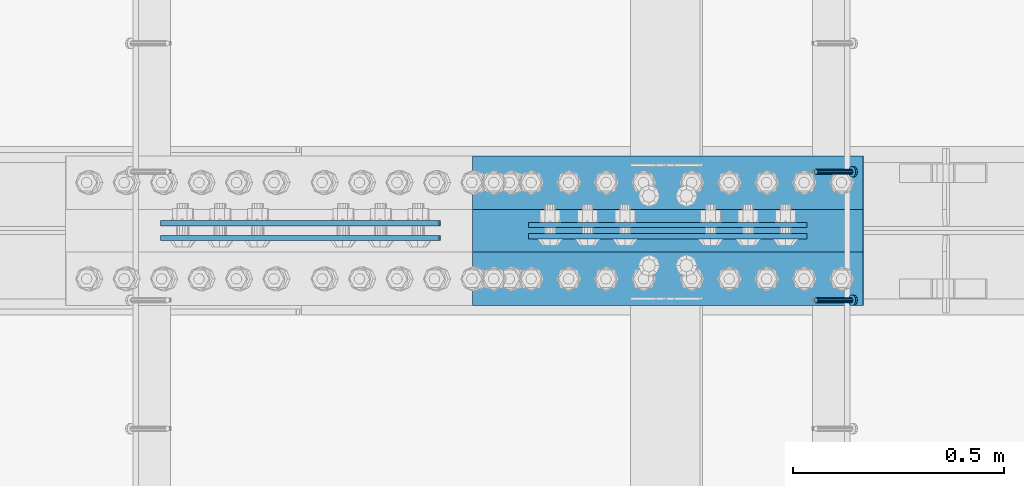
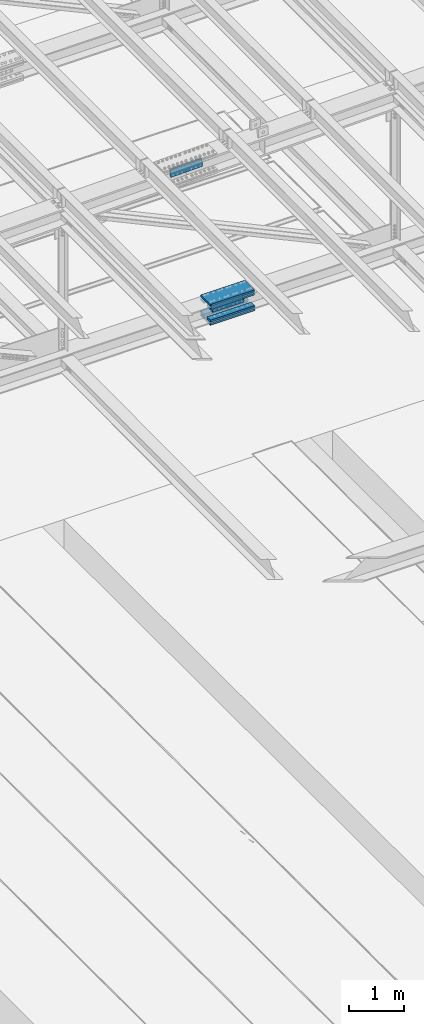
# One storey, part 2254 of 3843: 10 beams, 2 members, 3 elements without a shape of their own.
"""IFC2X3 building model written with IfcOpenShell, lengths in millimetres."""

import ifcopenshell
import ifcopenshell.guid

model = None  # the IFC model being written
_history = None  # IfcOwnerHistory: only IFC2X3 demands one
_inside = {}  # id of a spatial element -> (the spatial element, [elements in it])
_under = {}  # id of a project, library or spatial element -> (it, [spatial elements below it])
_declared = {}  # id of a project -> (the project, [libraries it declares])
_typed = {}  # id of a type object -> (the type object, [elements of that type])
_made_of = {}  # id of a material, layer set ... -> (it, [elements and type objects made of it])


def new_model(schema):
    """Start an empty IFC model of exactly this schema.

    Asked for "IFC4X3", IfcOpenShell would pick the latest addendum, in which some entities
    have other attributes; the version numbers below select the first issue.
    IFC2X3 requires an IfcOwnerHistory on every rooted entity: one is made here for all.
    """
    global model, _history
    if schema == "IFC4X3":
        model = ifcopenshell.file(schema_version=(4, 3, 0, 0))
    else:
        model = ifcopenshell.file(schema=schema)
    _inside.clear()
    _under.clear()
    _declared.clear()
    _typed.clear()
    _made_of.clear()
    _history = None
    if model.schema == "IFC2X3":
        org = make("IfcOrganization", Name="unknown")
        user = make(
            "IfcPersonAndOrganization",
            ThePerson=make("IfcPerson", FamilyName="unknown"),
            TheOrganization=org,
        )
        app = make(
            "IfcApplication",
            ApplicationDeveloper=org,
            Version="unknown",
            ApplicationFullName="unknown",
            ApplicationIdentifier="unknown",
        )
        _history = make(
            "IfcOwnerHistory",
            OwningUser=user,
            OwningApplication=app,
            ChangeAction="ADDED",
            CreationDate=0,
        )
    return model


def make(cls, **values):
    """One entity of the class cls with the attributes given. An attribute that is None is left unset."""
    return model.create_entity(
        cls, **{name: value for name, value in values.items() if value is not None}
    )


def rooted(cls, **values):
    """An entity with a GlobalId (a new one), such as an element, a storey or a relation."""
    return make(cls, GlobalId=ifcopenshell.guid.new(), OwnerHistory=_history, **values)


def si_unit(unit_type, name, prefix=None):
    """IfcSIUnit, for example si_unit("LENGTHUNIT", "METRE", prefix="MILLI")."""
    return make("IfcSIUnit", UnitType=unit_type, Prefix=prefix, Name=name)


def assignment(units):
    """IfcUnitAssignment: the units of a project."""
    return None if units is None else make("IfcUnitAssignment", Units=units)


def point(xyz):
    """IfcCartesianPoint."""
    return None if xyz is None else make("IfcCartesianPoint", Coordinates=xyz)


def direction(xyz):
    """IfcDirection."""
    return None if xyz is None else make("IfcDirection", DirectionRatios=xyz)


def frame(location, z_axis=None, x_axis=None):
    """IfcAxis2Placement3D, a coordinate frame: its origin and axes. An axis left out is left unset."""
    return make(
        "IfcAxis2Placement3D",
        Location=point(location),
        Axis=direction(z_axis),
        RefDirection=direction(x_axis),
    )


def origin_with_axes():
    """The frame at (0, 0, 0) with the z axis (0, 0, 1) and the x axis (1, 0, 0) written out."""
    return frame((0.0, 0.0, 0.0), z_axis=(0.0, 0.0, 1.0), x_axis=(1.0, 0.0, 0.0))


def place(relative_to, where):
    """IfcLocalPlacement: puts the frame where relative to a parent placement (None: the world)."""
    return make(
        "IfcLocalPlacement", PlacementRelTo=relative_to, RelativePlacement=where
    )


def context(
    kind, dimensions, precision=None, world=None, true_north=None, identifier=None
):
    """IfcGeometricRepresentationContext, for example the 3D "Model" context."""
    return make(
        "IfcGeometricRepresentationContext",
        ContextIdentifier=identifier,
        ContextType=kind,
        CoordinateSpaceDimension=dimensions,
        Precision=precision,
        WorldCoordinateSystem=world,
        TrueNorth=true_north,
    )


def subcontext(parent, identifier, kind, view, scale=None):
    """IfcGeometricRepresentationSubContext, for example "Body" below "Model"."""
    return make(
        "IfcGeometricRepresentationSubContext",
        ContextIdentifier=identifier,
        ContextType=kind,
        ParentContext=parent,
        TargetScale=scale,
        TargetView=view,
    )


def project(units=None, contexts=None):
    """IfcProject with its units and contexts."""
    return rooted(
        "IfcProject",
        Name="project",
        RepresentationContexts=contexts,
        UnitsInContext=assignment(units),
    )


def spatial(cls, under=None, at=None, **own):
    """A site, building, storey or space (cls), placed at a placement, below another one or the project."""
    s = rooted(cls, ObjectPlacement=at, **own)
    if under is not None:
        _under.setdefault(under.id(), (under, []))[1].append(s)
    return s


def faces_of(points, faces, orient=None, outer=None):
    """IfcFace entities. A face is a list of loops; a loop is a list of indices into points, from 0.

    orient and outer hold one flag for each loop. By default every Orientation is true, the
    first loop of a face is its IfcFaceOuterBound and the others are IfcFaceBound.
    """
    made = []
    for i, loops in enumerate(faces):
        bounds = []
        for j, loop in enumerate(loops):
            is_outer = j == 0 if outer is None else outer[i][j]
            bounds.append(
                make(
                    "IfcFaceOuterBound" if is_outer else "IfcFaceBound",
                    Bound=make("IfcPolyLoop", Polygon=[points[k] for k in loop]),
                    Orientation=True if orient is None else orient[i][j],
                )
            )
        made.append(make("IfcFace", Bounds=bounds))
    return made


def faceted_brep(points, faces, orient=None, outer=None, voids=None):
    """IfcFacetedBrep: a solid bounded by flat faces; with voids (closed shells), ...WithVoids."""
    shared = [point(p) for p in points]
    hull = make("IfcClosedShell", CfsFaces=faces_of(shared, faces, orient, outer))
    if voids is None:
        return make("IfcFacetedBrep", Outer=hull)
    return make(
        "IfcFacetedBrepWithVoids",
        Outer=hull,
        Voids=[
            make(cls, CfsFaces=faces_of(shared, fs, o, b)) for cls, fs, o, b in voids
        ],
    )


def shape(context_of_items, identifier, shape_type, items):
    """IfcShapeRepresentation: the items that make up one representation, for example the "Body"."""
    return make(
        "IfcShapeRepresentation",
        ContextOfItems=context_of_items,
        RepresentationIdentifier=identifier,
        RepresentationType=shape_type,
        Items=items,
    )


def material(Name=None, Category=None):
    """IfcMaterial."""
    return make("IfcMaterial", Name=Name, Category=Category)


def made_of(thing, what):
    """Note that an element or type object is made of a material, layer set ...; save() writes the relation."""
    if what is not None:
        _made_of.setdefault(what.id(), (what, []))[1].append(thing)
    return thing


def type_object(cls, material=None, **own):
    """A type object (cls), such as IfcWallType, which elements share."""
    return made_of(rooted(cls, **own), material)


def element(
    cls,
    number,
    at=None,
    inside=None,
    cuts=None,
    type_object=None,
    material=None,
    context=None,
    identifier="Body",
    shape_type=None,
    held_by="IfcProductDefinitionShape",
    body=None,
    shapes=None,
    **own,
):
    """One element of the class cls, such as IfcWall. Its Tag is "e" and its number.

    at: its placement. inside: the storey or other place that contains it. cuts: it is an
    opening in that element (IfcRelVoidsElement). A single representation is given by context,
    identifier, shape_type and body (its items); several are given by shapes. held_by: the class
    of the entity that holds the representations. save() writes the other relations.
    """
    e = rooted(cls, Tag="e%d" % number, ObjectPlacement=at, **own)
    if body is not None:
        shapes = [shape(context, identifier, shape_type, body)]
    if shapes is not None:
        e.Representation = make(held_by, Representations=shapes)
    if inside is not None:
        _inside.setdefault(inside.id(), (inside, []))[1].append(e)
    if cuts is not None:
        rooted(
            "IfcRelVoidsElement", RelatingBuildingElement=cuts, RelatedOpeningElement=e
        )
    if type_object is not None:
        _typed.setdefault(type_object.id(), (type_object, []))[1].append(e)
    return made_of(e, material)


def aggregate(whole, parts):
    """IfcRelAggregates: a whole, such as a stair, and the parts it consists of."""
    return rooted("IfcRelAggregates", RelatingObject=whole, RelatedObjects=parts)


def save(model, path):
    """Write the relations noted so far, then the file.

    IfcRelAggregates (storeys below a building ...), IfcRelContainedInSpatialStructure (elements
    in a storey), IfcRelDefinesByType, IfcRelAssociatesMaterial and IfcRelDeclares: one each for
    every whole, place, type object, material and project.
    """
    for whole, parts in _under.values():
        aggregate(whole, parts)
    for where, things in _inside.values():
        rooted(
            "IfcRelContainedInSpatialStructure",
            RelatedElements=things,
            RelatingStructure=where,
        )
    for kind, things in _typed.values():
        rooted("IfcRelDefinesByType", RelatedObjects=things, RelatingType=kind)
    for what, things in _made_of.values():
        rooted("IfcRelAssociatesMaterial", RelatedObjects=things, RelatingMaterial=what)
    for by, libraries in _declared.values():
        rooted("IfcRelDeclares", RelatingContext=by, RelatedDefinitions=libraries)
    model.write(path)


model = new_model("IFC2X3")

# Units and contexts
model_context = context("Model", 3, precision=1e-05, world=origin_with_axes())
body_context = subcontext(model_context, "Body", "Model", "MODEL_VIEW")
ifc_project = project(units=[si_unit("LENGTHUNIT", "METRE", prefix="MILLI"), si_unit("AREAUNIT", "SQUARE_METRE"), si_unit("VOLUMEUNIT", "CUBIC_METRE"), si_unit("MASSUNIT", "GRAM", prefix="KILO"), si_unit("TIMEUNIT", "SECOND"), si_unit("PLANEANGLEUNIT", "RADIAN"), si_unit("SOLIDANGLEUNIT", "STERADIAN"), si_unit("THERMODYNAMICTEMPERATUREUNIT", "DEGREE_CELSIUS"), si_unit("LUMINOUSINTENSITYUNIT", "LUMEN")], contexts=[model_context])

# Site, building, storey
site_placement = place(None, origin_with_axes())
site = spatial("IfcSite", under=ifc_project, at=site_placement, CompositionType="ELEMENT")
building_placement = place(site_placement, origin_with_axes())
building = spatial("IfcBuilding", under=site, at=building_placement, Name="Undefined", CompositionType="ELEMENT")
storey_placement = place(building_placement, origin_with_axes())
storey = spatial("IfcBuildingStorey", under=building, at=storey_placement, Name="Undefined", CompositionType="ELEMENT", Elevation=0.0)

# Assembly, members
assembly_1_placement = place(storey_placement, origin_with_axes())
assembly_1 = element("IfcElementAssembly", 1, at=assembly_1_placement, inside=storey, Name="EMBED_ANGLE", AssemblyPlace="NOTDEFINED", PredefinedType="RIGID_FRAME")
ifc_material_1 = material(Name="STEEL/A108")
member_type = type_object("IfcMemberType", PredefinedType="NOTDEFINED")
member_1_placement = place(assembly_1_placement, frame((52815.2360419921, 42036.9996154785, 30446.6625), z_axis=(0.0, 1.0, 0.0), x_axis=(0.707106781186548, 0.0, -0.707106781186548)))
member_1 = element("IfcMember", 2, at=member_1_placement, type_object=member_type, material=ifc_material_1, Name="HEADED STUD ANCHOR", context=body_context, shape_type="Brep", body=[
    faceted_brep([(7.27595761418343e-12, -3.18000006675175, 5.5), (0.0, -5.49999999998363, 3.1800000667572), (118.110000000976, -5.49999999999091, 3.1800000667572), (118.110000000983, -3.18000006675175, 5.5), (0.0, -6.3499999046162, 0.0), (118.110000000968, -6.34999990461256, 0.0), (0.0, -5.49999999998363, -3.1800000667572), (118.110000000976, -5.49999999999091, -3.1800000667572), (7.27595761418343e-12, -3.18000006675175, -5.5), (118.110000000983, -3.18000006675175, -5.5), (7.27595761418343e-12, -1.81898940354586e-12, -6.34999990463257), (118.110000000968, -1.81898940354586e-12, -6.34999990463257), (0.0, 3.18000006675175, -5.5), (118.110000000968, 3.18000006674811, -5.5), (7.27595761418343e-12, 5.49999999998363, -3.1800000667572), (118.110000000983, 5.49999999998363, -3.1800000667572), (7.27595761418343e-12, 6.3499999046162, 0.0), (118.110000000976, 6.34999990461256, 0.0), (7.27595761418343e-12, 5.49999999998363, 3.1800000667572), (118.110000000983, 5.49999999998363, 3.1800000667572), (0.0, 3.18000006675175, 5.5), (118.110000000968, 3.18000006674811, 5.5), (7.27595761418343e-12, -1.81898940354586e-12, 6.34999990463257), (118.110000000968, -1.81898940354586e-12, 6.34999990463257), (120.650000000991, -10.9899997710909, 6.34999990463257), (120.650000000998, -6.34000015257152, 10.9899997711182), (120.650000000991, -12.6999998092379, 0.0), (120.650000000991, -10.9899997710909, -6.34999990463257), (120.650000000998, -6.34000015257152, -10.9899997711182), (120.650000000991, -1.81898940354586e-12, -12.6899995803833), (120.650000000991, 6.34000015257152, -10.9899997711182), (120.650000000998, 10.9899997710909, -6.34999990463257), (120.650000000991, 12.6999998092342, 0.0), (120.650000000998, 10.9899997710909, 6.34999990463257), (120.650000000991, 6.34000015257152, 10.9899997711182), (120.650000000991, -1.81898940354586e-12, 12.6899995803833), (127.000000001048, -10.9899997710945, 6.34999990463257), (127.000000001048, -6.34000015257152, 10.9899997711182), (127.000000001048, -12.6999998092342, 0.0), (127.000000001048, -10.9899997710945, -6.34999990463257), (127.000000001048, -6.34000015257152, -10.9899997711182), (127.000000001048, 1.81898940354586e-12, -12.6899995803833), (127.000000001048, 6.34000015256788, -10.9899997711182), (127.000000001048, 10.9899997710909, -6.34999990463257), (127.000000001048, 12.6999998092379, 0.0), (127.000000001048, 10.9899997710909, 6.34999990463257), (127.000000001048, 6.34000015256788, 10.9899997711182), (127.000000001048, 1.81898940354586e-12, 12.6899995803833)], [[[0, 1, 2, 3]], [[1, 4, 5, 2]], [[4, 6, 7, 5]], [[6, 8, 9, 7]], [[8, 10, 11, 9]], [[10, 12, 13, 11]], [[12, 14, 15, 13]], [[14, 16, 17, 15]], [[16, 18, 19, 17]], [[18, 20, 21, 19]], [[20, 22, 23, 21]], [[22, 0, 3, 23]], [[22, 20, 18, 16, 14, 12, 10, 8, 6, 4, 1, 0]], [[3, 2, 24, 25]], [[2, 5, 26, 24]], [[5, 7, 27, 26]], [[7, 9, 28, 27]], [[9, 11, 29, 28]], [[11, 13, 30, 29]], [[13, 15, 31, 30]], [[15, 17, 32, 31]], [[17, 19, 33, 32]], [[19, 21, 34, 33]], [[21, 23, 35, 34]], [[23, 3, 25, 35]], [[25, 24, 36, 37]], [[24, 26, 38, 36]], [[26, 27, 39, 38]], [[27, 28, 40, 39]], [[28, 29, 41, 40]], [[29, 30, 42, 41]], [[30, 31, 43, 42]], [[31, 32, 44, 43]], [[32, 33, 45, 44]], [[33, 34, 46, 45]], [[34, 35, 47, 46]], [[35, 25, 37, 47]], [[38, 39, 40, 41, 42, 43, 44, 45, 46, 47, 37, 36]]]),
])
member_2_placement = place(assembly_1_placement, frame((52815.2360419921, 42341.7996154785, 30446.6625), z_axis=(0.0, 1.0, 0.0), x_axis=(0.707106781186548, 0.0, -0.707106781186548)))
member_2 = element("IfcMember", 3, at=member_2_placement, type_object=member_type, material=ifc_material_1, Name="HEADED STUD ANCHOR", context=body_context, shape_type="Brep", body=[
    faceted_brep([(7.27595761418343e-12, -3.18000006675175, 5.5), (0.0, -5.49999999998363, 3.1800000667572), (118.110000000976, -5.49999999999091, 3.1800000667572), (118.110000000983, -3.18000006675175, 5.5), (0.0, -6.3499999046162, 0.0), (118.110000000968, -6.34999990461256, 0.0), (0.0, -5.49999999998363, -3.1800000667572), (118.110000000976, -5.49999999999091, -3.1800000667572), (7.27595761418343e-12, -3.18000006675175, -5.5), (118.110000000983, -3.18000006675175, -5.5), (7.27595761418343e-12, -1.81898940354586e-12, -6.34999990463257), (118.110000000968, -1.81898940354586e-12, -6.34999990463257), (0.0, 3.18000006675175, -5.5), (118.110000000968, 3.18000006674811, -5.5), (7.27595761418343e-12, 5.49999999998363, -3.1800000667572), (118.110000000983, 5.49999999998363, -3.1800000667572), (7.27595761418343e-12, 6.3499999046162, 0.0), (118.110000000976, 6.34999990461256, 0.0), (7.27595761418343e-12, 5.49999999998363, 3.1800000667572), (118.110000000983, 5.49999999998363, 3.1800000667572), (0.0, 3.18000006675175, 5.5), (118.110000000968, 3.18000006674811, 5.5), (7.27595761418343e-12, -1.81898940354586e-12, 6.34999990463257), (118.110000000968, -1.81898940354586e-12, 6.34999990463257), (120.650000000991, -10.9899997710909, 6.34999990463257), (120.650000000998, -6.34000015257152, 10.9899997711182), (120.650000000991, -12.6999998092379, 0.0), (120.650000000991, -10.9899997710909, -6.34999990463257), (120.650000000998, -6.34000015257152, -10.9899997711182), (120.650000000991, -1.81898940354586e-12, -12.6899995803833), (120.650000000991, 6.34000015257152, -10.9899997711182), (120.650000000998, 10.9899997710909, -6.34999990463257), (120.650000000991, 12.6999998092342, 0.0), (120.650000000998, 10.9899997710909, 6.34999990463257), (120.650000000991, 6.34000015257152, 10.9899997711182), (120.650000000991, -1.81898940354586e-12, 12.6899995803833), (127.000000001048, -10.9899997710945, 6.34999990463257), (127.000000001048, -6.34000015257152, 10.9899997711182), (127.000000001048, -12.6999998092342, 0.0), (127.000000001048, -10.9899997710945, -6.34999990463257), (127.000000001048, -6.34000015257152, -10.9899997711182), (127.000000001048, 1.81898940354586e-12, -12.6899995803833), (127.000000001048, 6.34000015256788, -10.9899997711182), (127.000000001048, 10.9899997710909, -6.34999990463257), (127.000000001048, 12.6999998092379, 0.0), (127.000000001048, 10.9899997710909, 6.34999990463257), (127.000000001048, 6.34000015256788, 10.9899997711182), (127.000000001048, 1.81898940354586e-12, 12.6899995803833)], [[[0, 1, 2, 3]], [[1, 4, 5, 2]], [[4, 6, 7, 5]], [[6, 8, 9, 7]], [[8, 10, 11, 9]], [[10, 12, 13, 11]], [[12, 14, 15, 13]], [[14, 16, 17, 15]], [[16, 18, 19, 17]], [[18, 20, 21, 19]], [[20, 22, 23, 21]], [[22, 0, 3, 23]], [[22, 20, 18, 16, 14, 12, 10, 8, 6, 4, 1, 0]], [[3, 2, 24, 25]], [[2, 5, 26, 24]], [[5, 7, 27, 26]], [[7, 9, 28, 27]], [[9, 11, 29, 28]], [[11, 13, 30, 29]], [[13, 15, 31, 30]], [[15, 17, 32, 31]], [[17, 19, 33, 32]], [[19, 21, 34, 33]], [[21, 23, 35, 34]], [[23, 3, 25, 35]], [[25, 24, 36, 37]], [[24, 26, 38, 36]], [[26, 27, 39, 38]], [[27, 28, 40, 39]], [[28, 29, 41, 40]], [[29, 30, 42, 41]], [[30, 31, 43, 42]], [[31, 32, 44, 43]], [[32, 33, 45, 44]], [[33, 34, 46, 45]], [[34, 35, 47, 46]], [[35, 25, 37, 47]], [[38, 39, 40, 41, 42, 43, 44, 45, 46, 47, 37, 36]]]),
])
aggregate(assembly_1, [member_1, member_2])

# Assembly, beam
assembly_2_placement = place(storey_placement, origin_with_axes())
assembly_2 = element("IfcElementAssembly", 4, at=assembly_2_placement, inside=storey, Name="BEAM", AssemblyPlace="NOTDEFINED", PredefinedType="RIGID_FRAME")
ifc_material_2 = material(Name="STEEL/A572-50")
beam_type_1 = type_object("IfcBeamType", PredefinedType="NOTDEFINED")
beam_1_placement = place(assembly_2_placement, frame((52793.8989371824, 42188.60625, 42309.1609550834), z_axis=(0.00254243700000369, 0.0, -0.999996768001828), x_axis=(-0.999996768001828, 0.0, -0.00254243700000061)))
beam_1 = element("IfcBeam", 5, at=beam_1_placement, type_object=beam_type_1, material=ifc_material_2, Name="PLATE", context=body_context, shape_type="Brep", body=[
    faceted_brep([(1.45519152283669e-11, 6.35000000000582, -88.8999999998996), (0.0, 6.34999999999854, 88.9000015258789), (660.399999982677, 6.35000000000582, 88.8999999999651), (660.399999982707, 6.35000000000582, -88.8999999998268), (0.0, -6.34999999999854, 88.9000015258789), (660.399999982677, -6.35000000000582, 88.8999999999651), (1.45519152283669e-11, -6.35000000000582, -88.8999999998996), (660.399999982707, -6.35000000000582, -88.8999999998268)], [[[0, 1, 2, 3]], [[1, 4, 5, 2]], [[4, 6, 7, 5]], [[6, 0, 3, 7]], [[5, 7, 3, 2]], [[6, 4, 1, 0]]]),
])

# Assembly, beams
assembly_3_placement = place(storey_placement, origin_with_axes())
assembly_3 = element("IfcElementAssembly", 6, at=assembly_3_placement, inside=storey, Name="BEAM", AssemblyPlace="NOTDEFINED", PredefinedType="RIGID_FRAME")
beam_2_placement = place(assembly_3_placement, frame((51922.1993812498, 42219.5625, 45606.5159153784), z_axis=(0.023840473988268, 0.0, -0.999715775508227), x_axis=(-0.999715775508227, 0.0, -0.0238404739882678)))
beam_2 = element("IfcBeam", 7, at=beam_2_placement, type_object=beam_type_1, material=ifc_material_2, Name="PLATE", context=body_context, shape_type="Brep", body=[
    faceted_brep([(1.45519152283669e-11, 6.35000000000582, -88.8999999998996), (0.0, 6.34999999999854, 88.9000015258789), (660.399999982677, 6.35000000000582, 88.8999999999651), (660.399999982707, 6.35000000000582, -88.8999999998268), (0.0, -6.34999999999854, 88.9000015258789), (660.399999982677, -6.35000000000582, 88.8999999999651), (1.45519152283669e-11, -6.35000000000582, -88.8999999998996), (660.399999982707, -6.35000000000582, -88.8999999998268)], [[[0, 1, 2, 3]], [[1, 4, 5, 2]], [[4, 6, 7, 5]], [[6, 0, 3, 7]], [[5, 7, 3, 2]], [[6, 4, 1, 0]]]),
])
beam_3_placement = place(assembly_3_placement, frame((51922.1993812498, 42184.6375, 45606.5159153784), z_axis=(0.023840473988268, 0.0, -0.999715775508227), x_axis=(-0.999715775508227, 0.0, -0.0238404739882678)))
beam_3 = element("IfcBeam", 8, at=beam_3_placement, type_object=beam_type_1, material=ifc_material_2, Name="PLATE", context=body_context, shape_type="Brep", body=[
    faceted_brep([(1.45519152283669e-11, 6.35000000000582, -88.8999999998996), (0.0, 6.34999999999854, 88.9000015258789), (660.399999982677, 6.35000000000582, 88.8999999999651), (660.399999982707, 6.35000000000582, -88.8999999998268), (0.0, -6.34999999999854, 88.9000015258789), (660.399999982677, -6.35000000000582, 88.8999999999651), (1.45519152283669e-11, -6.35000000000582, -88.8999999998996), (660.399999982707, -6.35000000000582, -88.8999999998268)], [[[0, 1, 2, 3]], [[1, 4, 5, 2]], [[4, 6, 7, 5]], [[6, 0, 3, 7]], [[5, 7, 3, 2]], [[6, 4, 1, 0]]]),
])
aggregate(assembly_3, [beam_2, beam_3])

# Beam
beam_4_placement = place(assembly_2_placement, frame((52793.8989371824, 42215.59375, 42309.1609550834), z_axis=(0.00254243700000369, 0.0, -0.999996768001828), x_axis=(-0.999996768001828, 0.0, -0.00254243700000061)))
beam_4 = element("IfcBeam", 9, at=beam_4_placement, type_object=beam_type_1, material=ifc_material_2, Name="PLATE", context=body_context, shape_type="Brep", body=[
    faceted_brep([(1.45519152283669e-11, 6.35000000000582, -88.8999999998996), (0.0, 6.34999999999854, 88.9000015258789), (660.399999982677, 6.35000000000582, 88.8999999999651), (660.399999982707, 6.35000000000582, -88.8999999998268), (0.0, -6.34999999999854, 88.9000015258789), (660.399999982677, -6.35000000000582, 88.8999999999651), (1.45519152283669e-11, -6.35000000000582, -88.8999999998996), (660.399999982707, -6.35000000000582, -88.8999999998268)], [[[0, 1, 2, 3]], [[1, 4, 5, 2]], [[4, 6, 7, 5]], [[6, 0, 3, 7]], [[5, 7, 3, 2]], [[6, 4, 1, 0]]]),
])

beam_type_2 = type_object("IfcBeamType", PredefinedType="NOTDEFINED")
beam_5_placement = place(assembly_2_placement, frame((52926.723806085, 42202.1, 42515.8734737471), z_axis=(0.0, -1.0, 0.0), x_axis=(-0.999996768001828, 0.0, -0.00254243700000061)))
beam_5 = element("IfcBeam", 10, at=beam_5_placement, type_object=beam_type_2, material=ifc_material_2, Name="PLATE", context=body_context, shape_type="Brep", body=[
    faceted_brep([(0.0, 22.2249999999767, -177.800000000003), (0.0, 22.2249999999767, 177.800000000003), (927.099999958984, 22.2250000000859, 177.800000000003), (927.099999958984, 22.2250000000859, -177.800000000003), (0.0, -22.2249999999694, 177.800000000003), (927.099999958984, -22.2249999998749, 177.800000000003), (0.0, -22.2249999999694, -177.800000000003), (927.099999958984, -22.2249999998749, -177.800000000003)], [[[0, 1, 2, 3]], [[1, 4, 5, 2]], [[4, 6, 7, 5]], [[6, 0, 3, 7]], [[5, 7, 3, 2]], [[6, 4, 1, 0]]]),
])

beam_6_placement = place(assembly_2_placement, frame((52927.7760498986, 42202.1, 42103.0656149804), z_axis=(0.0, -1.0, 0.0), x_axis=(-0.999996768001828, 0.0, -0.00254243700000061)))
beam_6 = element("IfcBeam", 11, at=beam_6_placement, type_object=beam_type_2, material=ifc_material_2, Name="PLATE", context=body_context, shape_type="Brep", body=[
    faceted_brep([(0.0, 22.2249999999767, -177.800000000003), (0.0, 22.2249999999767, 177.800000000003), (927.099999958984, 22.2250000000859, 177.800000000003), (927.099999958984, 22.2250000000859, -177.800000000003), (0.0, -22.2249999999694, 177.800000000003), (927.099999958984, -22.2249999998749, 177.800000000003), (0.0, -22.2249999999694, -177.800000000003), (927.099999958984, -22.2249999998749, -177.800000000003)], [[[0, 1, 2, 3]], [[1, 4, 5, 2]], [[4, 6, 7, 5]], [[6, 0, 3, 7]], [[5, 7, 3, 2]], [[6, 4, 1, 0]]]),
])

beam_type_3 = type_object("IfcBeamType", PredefinedType="NOTDEFINED")
beam_7_placement = place(assembly_2_placement, frame((51999.8005140064, 42316.4, 42445.1926762636), z_axis=(0.0, -1.0, 0.0), x_axis=(0.999996768001828, 0.0, 0.00254243700000616)))
beam_7 = element("IfcBeam", 12, at=beam_7_placement, type_object=beam_type_3, material=ifc_material_2, Name="PLATE", context=body_context, shape_type="Brep", body=[
    faceted_brep([(-7.27595761418343e-11, 22.2250000000786, -63.5), (-7.27595761418343e-11, 22.2250000000786, 63.5), (927.099999951592, 22.2250000031054, 63.5), (927.099999951592, 22.2250000031054, -63.5), (6.54836185276508e-11, -22.2250000000713, 63.5), (927.099999951744, -22.2249999970372, 63.5), (6.54836185276508e-11, -22.2250000000713, -63.5), (927.099999951744, -22.2249999970372, -63.5)], [[[0, 1, 2, 3]], [[1, 4, 5, 2]], [[4, 6, 7, 5]], [[6, 0, 3, 7]], [[5, 7, 3, 2]], [[6, 4, 1, 0]]]),
])

beam_8_placement = place(assembly_2_placement, frame((52000.50280223, 42316.4, 42168.9707638302), z_axis=(0.0, -1.0, 0.0), x_axis=(0.999996768001828, 0.0, 0.00254243700000616)))
beam_8 = element("IfcBeam", 13, at=beam_8_placement, type_object=beam_type_3, material=ifc_material_2, Name="PLATE", context=body_context, shape_type="Brep", body=[
    faceted_brep([(-7.27595761418343e-11, 22.2250000000786, -63.5), (-7.27595761418343e-11, 22.2250000000786, 63.5), (927.099999951592, 22.2250000031054, 63.5), (927.099999951592, 22.2250000031054, -63.5), (6.54836185276508e-11, -22.2250000000713, 63.5), (927.099999951744, -22.2249999970372, 63.5), (6.54836185276508e-11, -22.2250000000713, -63.5), (927.099999951744, -22.2249999970372, -63.5)], [[[0, 1, 2, 3]], [[1, 4, 5, 2]], [[4, 6, 7, 5]], [[6, 0, 3, 7]], [[5, 7, 3, 2]], [[6, 4, 1, 0]]]),
])

beam_9_placement = place(assembly_2_placement, frame((51999.8005140064, 42087.8, 42445.1926762636), z_axis=(0.0, -1.0, 0.0), x_axis=(0.999996768001828, 0.0, 0.00254243700000616)))
beam_9 = element("IfcBeam", 14, at=beam_9_placement, type_object=beam_type_3, material=ifc_material_2, Name="PLATE", context=body_context, shape_type="Brep", body=[
    faceted_brep([(-7.27595761418343e-11, 22.2250000000786, -63.5), (-7.27595761418343e-11, 22.2250000000786, 63.5), (927.099999951592, 22.2250000031054, 63.5), (927.099999951592, 22.2250000031054, -63.5), (6.54836185276508e-11, -22.2250000000713, 63.5), (927.099999951744, -22.2249999970372, 63.5), (6.54836185276508e-11, -22.2250000000713, -63.5), (927.099999951744, -22.2249999970372, -63.5)], [[[0, 1, 2, 3]], [[1, 4, 5, 2]], [[4, 6, 7, 5]], [[6, 0, 3, 7]], [[5, 7, 3, 2]], [[6, 4, 1, 0]]]),
])

beam_10_placement = place(assembly_2_placement, frame((52000.50280223, 42087.8, 42168.9707638302), z_axis=(0.0, -1.0, 0.0), x_axis=(0.999996768001828, 0.0, 0.00254243700000616)))
beam_10 = element("IfcBeam", 15, at=beam_10_placement, type_object=beam_type_3, material=ifc_material_2, Name="PLATE", context=body_context, shape_type="Brep", body=[
    faceted_brep([(-7.27595761418343e-11, 22.2250000000786, -63.5), (-7.27595761418343e-11, 22.2250000000786, 63.5), (927.099999951592, 22.2250000031054, 63.5), (927.099999951592, 22.2250000031054, -63.5), (6.54836185276508e-11, -22.2250000000713, 63.5), (927.099999951744, -22.2249999970372, 63.5), (6.54836185276508e-11, -22.2250000000713, -63.5), (927.099999951744, -22.2249999970372, -63.5)], [[[0, 1, 2, 3]], [[1, 4, 5, 2]], [[4, 6, 7, 5]], [[6, 0, 3, 7]], [[5, 7, 3, 2]], [[6, 4, 1, 0]]]),
])

aggregate(assembly_2, [beam_1, beam_5, beam_7, beam_8, beam_9, beam_10, beam_4, beam_6])

save(model, "model.ifc")
